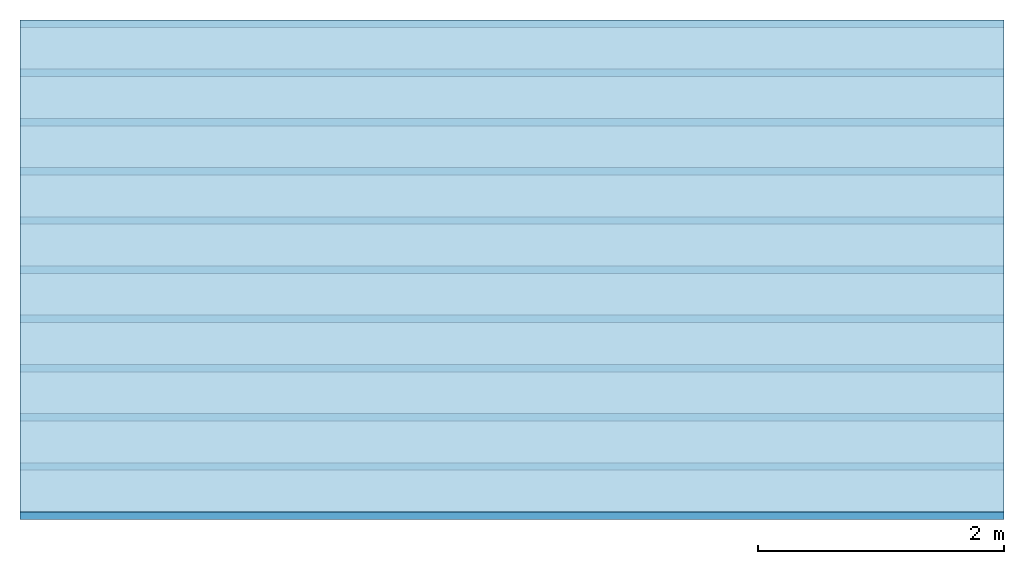
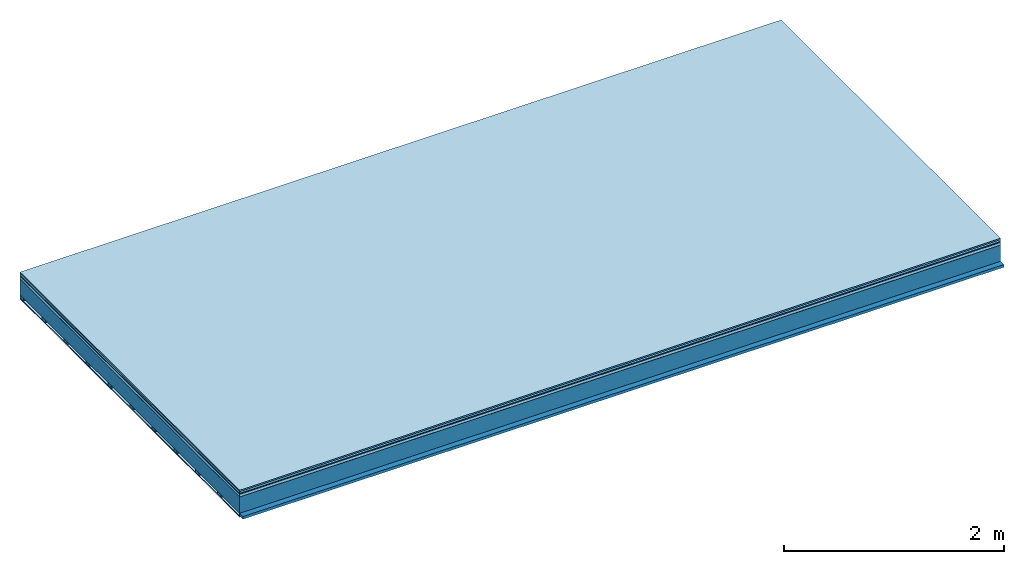
# One storey: 7 plates, 2 members, 1 element without a shape of its own.
"""IFC4 building model written with IfcOpenShell, lengths in metres."""

from ifc_helpers import new_model, si_unit, derived_unit, direction, frame, frame_2d, origin, origin_with_axes, place, context, project, spatial, rectangle, extrude, material, layer, layer_set, type_object, element, aggregate, save


model = new_model("IFC4")

# Units and contexts
plan_context = context("Plan", 3, precision=1e-05, world=origin(), true_north=direction((0.0, 1.0)))
model_context = context("Model", 3, precision=1e-05, world=origin(), true_north=direction((0.0, 1.0)))
ifc_project = project(units=[si_unit("LENGTHUNIT", "METRE"), derived_unit("SOUNDPRESSUREUNIT", [(si_unit("PRESSUREUNIT", "PASCAL", prefix="MICRO"), 0)]), si_unit("ENERGYUNIT", "JOULE", prefix="MEGA"), si_unit("MASSUNIT", "GRAM", prefix="KILO"), derived_unit("THERMALTRANSMITTANCEUNIT", [(si_unit("POWERUNIT", "WATT"), 1), (si_unit("AREAUNIT", "SQUARE_METRE"), -1), (si_unit("THERMODYNAMICTEMPERATUREUNIT", "KELVIN"), -1)]), derived_unit("AREADENSITYUNIT", [(si_unit("MASSUNIT", "GRAM", prefix="KILO"), 1), (si_unit("AREAUNIT", "SQUARE_METRE"), -1)]), derived_unit("USERDEFINED", [(si_unit("ENERGYUNIT", "JOULE", prefix="MEGA"), 1), (si_unit("AREAUNIT", "SQUARE_METRE"), -1)])], contexts=[plan_context, model_context])

# Site, building, storey
site = spatial("IfcSite", under=ifc_project)
building_placement = place(None, origin())
building = spatial("IfcBuilding", under=site, at=building_placement)
storey_placement = place(building_placement, origin())
storey = spatial("IfcBuildingStorey", under=building, at=storey_placement)

# Slab, members, plates
ifc_material_1 = material(Category="11.013")
ifc_layer_1 = layer(ifc_material_1, 0.015, Name="Flooring")
ifc_material_2 = material(Category="03.007")
ifc_layer_2 = layer(ifc_material_2, 0.02, Name="On-material")
ifc_material_3 = material(Name="Wood fiber generic product", Category="10.009")
ifc_layer_3 = layer(ifc_material_3, 0.01, Name="Impact sound insulation")
ifc_material_4 = material(Name="with broken")
ifc_layer_4 = layer(ifc_material_4, 0.03, Name="on Supporting structure")
ifc_material_5 = material(Name="protection", Category="09.007")
ifc_layer_5 = layer(ifc_material_5, 0.0005, Name="Sub-floor")
ifc_material_6 = material(Name="no composite action")
ifc_layer_6 = layer(ifc_material_6, 0.0, Name="Bond")
ifc_layer_7 = layer(None, 0.18, Name="Supporting structure")
ifc_material_7 = material(Name="of the art")
ifc_layer_8 = layer(ifc_material_7, 0.0, Name="Bond")
ifc_layer_9 = layer(None, 0.03, Name="Battens / profiles")
ifc_material_8 = material(Name="Plasterboard type A", Category="03.008")
ifc_layer_10 = layer(ifc_material_8, 0.0125, Name="Ceiling covering 1st layer")
ifc_material_9 = material(Category="04.001")
ifc_layer_11 = layer(ifc_material_9, 0.003, Name="Surface / treatment")
ifc_layer_set = layer_set([ifc_layer_1, ifc_layer_2, ifc_layer_3, ifc_layer_4, ifc_layer_5, ifc_layer_6, ifc_layer_7, ifc_layer_8, ifc_layer_9, ifc_layer_10, ifc_layer_11])
slab_type = type_object("IfcSlabType", Name="A2108", PredefinedType="NOTDEFINED", material=ifc_layer_set)
slab_placement = place(None, frame((0.0, 0.0, 0.0), z_axis=(0.0, 0.0, -1.0), x_axis=(1.0, 0.0, 0.0)))
slab = element("IfcSlab", 1, at=slab_placement, inside=storey, type_object=slab_type, material=ifc_layer_set, Name="Slab #1")
ifc_material_10 = material(Name="Solid timber panel")
member_1_placement = place(slab_placement, origin())
member_1 = element("IfcMember", 2, at=member_1_placement, material=ifc_material_10, Name="Supporting structure", context=plan_context, shape_type="SweptSolid", body=[
    extrude(rectangle(XDim=1.0, YDim=0.18, at=frame_2d((0.5, 0.09), x_axis=(1.0, 0.0))), frame((0.0, 4.0, 0.0755), z_axis=(0.0, -1.0, 0.0), x_axis=(1.0, 0.0, 0.0)), (0.0, 0.0, 1.0), 4.0),
    extrude(rectangle(XDim=1.0, YDim=0.18, at=frame_2d((0.5, 0.09), x_axis=(1.0, 0.0))), frame((1.0, 4.0, 0.0755), z_axis=(0.0, -1.0, 0.0), x_axis=(1.0, 0.0, 0.0)), (0.0, 0.0, 1.0), 4.0),
    extrude(rectangle(XDim=1.0, YDim=0.18, at=frame_2d((0.5, 0.09), x_axis=(1.0, 0.0))), frame((2.0, 4.0, 0.0755), z_axis=(0.0, -1.0, 0.0), x_axis=(1.0, 0.0, 0.0)), (0.0, 0.0, 1.0), 4.0),
    extrude(rectangle(XDim=1.0, YDim=0.18, at=frame_2d((0.5, 0.09), x_axis=(1.0, 0.0))), frame((3.0, 4.0, 0.0755), z_axis=(0.0, -1.0, 0.0), x_axis=(1.0, 0.0, 0.0)), (0.0, 0.0, 1.0), 4.0),
    extrude(rectangle(XDim=1.0, YDim=0.18, at=frame_2d((0.5, 0.09), x_axis=(1.0, 0.0))), frame((4.0, 4.0, 0.0755), z_axis=(0.0, -1.0, 0.0), x_axis=(1.0, 0.0, 0.0)), (0.0, 0.0, 1.0), 4.0),
    extrude(rectangle(XDim=1.0, YDim=0.18, at=frame_2d((0.5, 0.09), x_axis=(1.0, 0.0))), frame((5.0, 4.0, 0.0755), z_axis=(0.0, -1.0, 0.0), x_axis=(1.0, 0.0, 0.0)), (0.0, 0.0, 1.0), 4.0),
    extrude(rectangle(XDim=1.0, YDim=0.18, at=frame_2d((0.5, 0.09), x_axis=(1.0, 0.0))), frame((6.0, 4.0, 0.0755), z_axis=(0.0, -1.0, 0.0), x_axis=(1.0, 0.0, 0.0)), (0.0, 0.0, 1.0), 4.0),
    extrude(rectangle(XDim=1.0, YDim=0.18, at=frame_2d((0.5, 0.09), x_axis=(1.0, 0.0))), frame((7.0, 4.0, 0.0755), z_axis=(0.0, -1.0, 0.0), x_axis=(1.0, 0.0, 0.0)), (0.0, 0.0, 1.0), 4.0),
])
ifc_material_11 = material()
member_2_placement = place(slab_placement, origin())
member_2 = element("IfcMember", 3, at=member_2_placement, material=ifc_material_11, Name="Battens / profiles", context=plan_context, shape_type="SweptSolid", body=[
    extrude(rectangle(XDim=0.06, YDim=0.03, at=frame_2d((0.03, 0.015), x_axis=(1.0, 0.0))), frame((0.0, 0.0, 0.2555), z_axis=(1.0, 0.0, 0.0), x_axis=(0.0, 1.0, 0.0)), (0.0, 0.0, 1.0), 8.0),
    extrude(rectangle(XDim=0.06, YDim=0.03, at=frame_2d((0.03, 0.015), x_axis=(1.0, 0.0))), frame((0.0, 0.4, 0.2555), z_axis=(1.0, 0.0, 0.0), x_axis=(0.0, 1.0, 0.0)), (0.0, 0.0, 1.0), 8.0),
    extrude(rectangle(XDim=0.06, YDim=0.03, at=frame_2d((0.03, 0.015), x_axis=(1.0, 0.0))), frame((0.0, 0.8, 0.2555), z_axis=(1.0, 0.0, 0.0), x_axis=(0.0, 1.0, 0.0)), (0.0, 0.0, 1.0), 8.0),
    extrude(rectangle(XDim=0.06, YDim=0.03, at=frame_2d((0.03, 0.015), x_axis=(1.0, 0.0))), frame((0.0, 1.2, 0.2555), z_axis=(1.0, 0.0, 0.0), x_axis=(0.0, 1.0, 0.0)), (0.0, 0.0, 1.0), 8.0),
    extrude(rectangle(XDim=0.06, YDim=0.03, at=frame_2d((0.03, 0.015), x_axis=(1.0, 0.0))), frame((0.0, 1.6, 0.2555), z_axis=(1.0, 0.0, 0.0), x_axis=(0.0, 1.0, 0.0)), (0.0, 0.0, 1.0), 8.0),
    extrude(rectangle(XDim=0.06, YDim=0.03, at=frame_2d((0.03, 0.015), x_axis=(1.0, 0.0))), frame((0.0, 2.0, 0.2555), z_axis=(1.0, 0.0, 0.0), x_axis=(0.0, 1.0, 0.0)), (0.0, 0.0, 1.0), 8.0),
    extrude(rectangle(XDim=0.06, YDim=0.03, at=frame_2d((0.03, 0.015), x_axis=(1.0, 0.0))), frame((0.0, 2.4, 0.2555), z_axis=(1.0, 0.0, 0.0), x_axis=(0.0, 1.0, 0.0)), (0.0, 0.0, 1.0), 8.0),
    extrude(rectangle(XDim=0.06, YDim=0.03, at=frame_2d((0.03, 0.015), x_axis=(1.0, 0.0))), frame((0.0, 2.8, 0.2555), z_axis=(1.0, 0.0, 0.0), x_axis=(0.0, 1.0, 0.0)), (0.0, 0.0, 1.0), 8.0),
    extrude(rectangle(XDim=0.06, YDim=0.03, at=frame_2d((0.03, 0.015), x_axis=(1.0, 0.0))), frame((0.0, 3.2, 0.2555), z_axis=(1.0, 0.0, 0.0), x_axis=(0.0, 1.0, 0.0)), (0.0, 0.0, 1.0), 8.0),
    extrude(rectangle(XDim=0.06, YDim=0.03, at=frame_2d((0.03, 0.015), x_axis=(1.0, 0.0))), frame((0.0, 3.6, 0.2555), z_axis=(1.0, 0.0, 0.0), x_axis=(0.0, 1.0, 0.0)), (0.0, 0.0, 1.0), 8.0),
    extrude(rectangle(XDim=0.06, YDim=0.03, at=frame_2d((0.03, 0.015), x_axis=(1.0, 0.0))), frame((0.0, 4.0, 0.2555), z_axis=(1.0, 0.0, 0.0), x_axis=(0.0, 1.0, 0.0)), (0.0, 0.0, 1.0), 8.0),
])
plate_1_placement = place(slab_placement, origin())
plate_1 = element("IfcPlate", 4, at=plate_1_placement, material=ifc_material_1, Name="Flooring", context=plan_context, shape_type="SweptSolid", body=[
    extrude(rectangle(XDim=8.0, YDim=4.0, at=frame_2d((4.0, 2.0), x_axis=(1.0, 0.0))), origin_with_axes(), (0.0, 0.0, 1.0), 0.015),
])
plate_2_placement = place(slab_placement, origin())
plate_2 = element("IfcPlate", 5, at=plate_2_placement, material=ifc_material_2, Name="On-material", context=plan_context, shape_type="SweptSolid", body=[
    extrude(rectangle(XDim=8.0, YDim=4.0, at=frame_2d((4.0, 2.0), x_axis=(1.0, 0.0))), frame((0.0, 0.0, 0.015), z_axis=(0.0, 0.0, 1.0), x_axis=(1.0, 0.0, 0.0)), (0.0, 0.0, 1.0), 0.02),
])
plate_3_placement = place(slab_placement, origin())
plate_3 = element("IfcPlate", 6, at=plate_3_placement, material=ifc_material_3, Name="Impact sound insulation", context=plan_context, shape_type="SweptSolid", body=[
    extrude(rectangle(XDim=8.0, YDim=4.0, at=frame_2d((4.0, 2.0), x_axis=(1.0, 0.0))), frame((0.0, 0.0, 0.035), z_axis=(0.0, 0.0, 1.0), x_axis=(1.0, 0.0, 0.0)), (0.0, 0.0, 1.0), 0.01),
])
plate_4_placement = place(slab_placement, origin())
plate_4 = element("IfcPlate", 7, at=plate_4_placement, material=ifc_material_4, Name="on Supporting structure", context=plan_context, shape_type="SweptSolid", body=[
    extrude(rectangle(XDim=8.0, YDim=4.0, at=frame_2d((4.0, 2.0), x_axis=(1.0, 0.0))), frame((0.0, 0.0, 0.045), z_axis=(0.0, 0.0, 1.0), x_axis=(1.0, 0.0, 0.0)), (0.0, 0.0, 1.0), 0.03),
])
plate_5_placement = place(slab_placement, origin())
plate_5 = element("IfcPlate", 8, at=plate_5_placement, material=ifc_material_5, Name="Sub-floor", context=plan_context, shape_type="SweptSolid", body=[
    extrude(rectangle(XDim=8.0, YDim=4.0, at=frame_2d((4.0, 2.0), x_axis=(1.0, 0.0))), frame((0.0, 0.0, 0.075), z_axis=(0.0, 0.0, 1.0), x_axis=(1.0, 0.0, 0.0)), (0.0, 0.0, 1.0), 0.0005),
])
plate_6_placement = place(slab_placement, origin())
plate_6 = element("IfcPlate", 9, at=plate_6_placement, material=ifc_material_8, Name="Ceiling covering 1st layer", context=plan_context, shape_type="SweptSolid", body=[
    extrude(rectangle(XDim=8.0, YDim=4.0, at=frame_2d((4.0, 2.0), x_axis=(1.0, 0.0))), frame((0.0, 0.0, 0.2855), z_axis=(0.0, 0.0, 1.0), x_axis=(1.0, 0.0, 0.0)), (0.0, 0.0, 1.0), 0.0125),
])
plate_7_placement = place(slab_placement, origin())
plate_7 = element("IfcPlate", 10, at=plate_7_placement, material=ifc_material_9, Name="Surface / treatment", context=plan_context, shape_type="SweptSolid", body=[
    extrude(rectangle(XDim=8.0, YDim=4.0, at=frame_2d((4.0, 2.0), x_axis=(1.0, 0.0))), frame((0.0, 0.0, 0.298), z_axis=(0.0, 0.0, 1.0), x_axis=(1.0, 0.0, 0.0)), (0.0, 0.0, 1.0), 0.003),
])
aggregate(slab, [plate_1, plate_2, plate_3, plate_4, plate_5, member_1, member_2, plate_6, plate_7])

save(model, "model.ifc")
